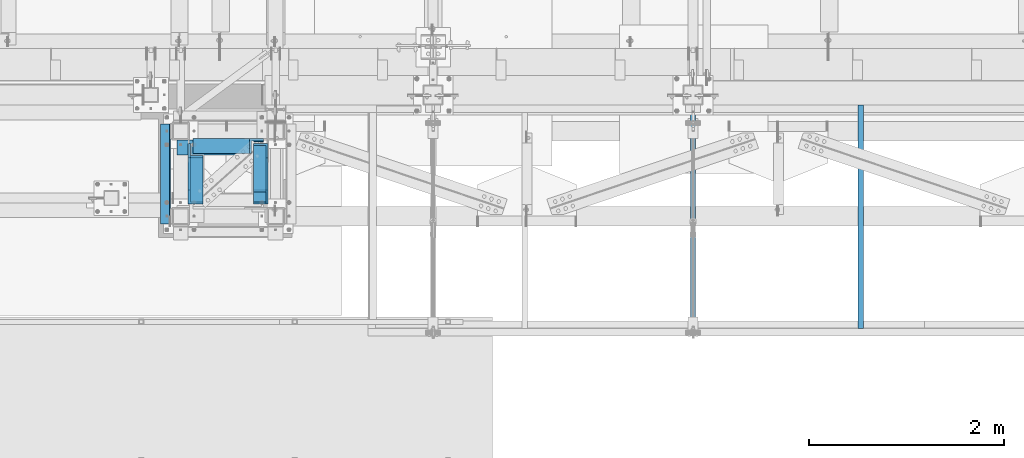
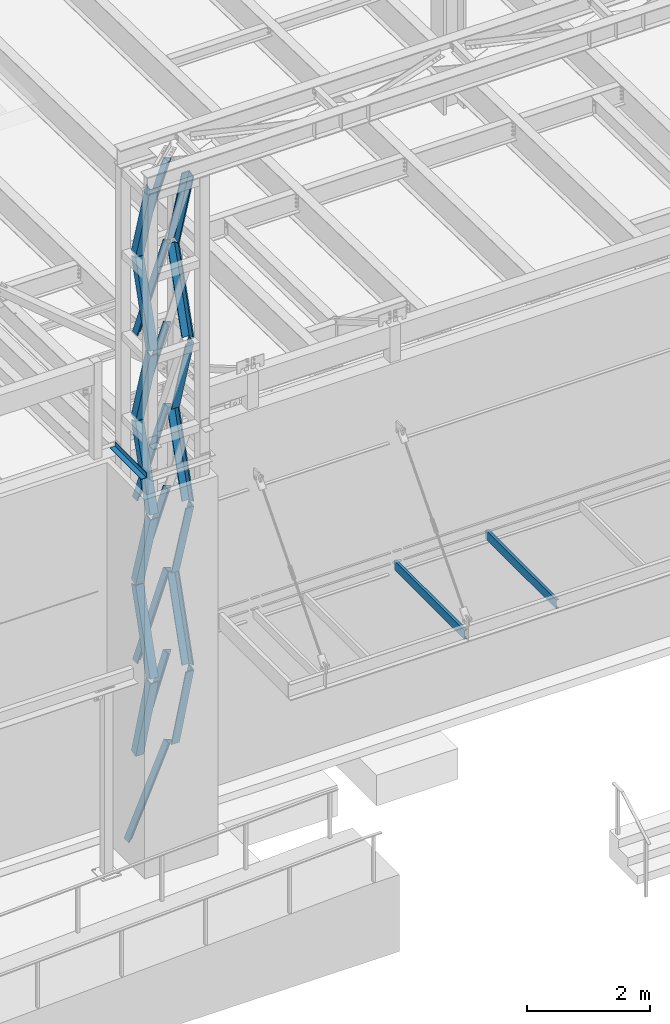
# One storey, part 1053 of 1763: 22 members, 3 beams, 3 elements without a shape of their own.
"""IFC2X3 building model written with IfcOpenShell, lengths in millimetres."""

import ifcopenshell
import ifcopenshell.guid

model = None  # the IFC model being written
_history = None  # IfcOwnerHistory: only IFC2X3 demands one
_inside = {}  # id of a spatial element -> (the spatial element, [elements in it])
_under = {}  # id of a project, library or spatial element -> (it, [spatial elements below it])
_declared = {}  # id of a project -> (the project, [libraries it declares])
_typed = {}  # id of a type object -> (the type object, [elements of that type])
_made_of = {}  # id of a material, layer set ... -> (it, [elements and type objects made of it])


def new_model(schema):
    """Start an empty IFC model of exactly this schema.

    Asked for "IFC4X3", IfcOpenShell would pick the latest addendum, in which some entities
    have other attributes; the version numbers below select the first issue.
    IFC2X3 requires an IfcOwnerHistory on every rooted entity: one is made here for all.
    """
    global model, _history
    if schema == "IFC4X3":
        model = ifcopenshell.file(schema_version=(4, 3, 0, 0))
    else:
        model = ifcopenshell.file(schema=schema)
    _inside.clear()
    _under.clear()
    _declared.clear()
    _typed.clear()
    _made_of.clear()
    _history = None
    if model.schema == "IFC2X3":
        org = make("IfcOrganization", Name="unknown")
        user = make(
            "IfcPersonAndOrganization",
            ThePerson=make("IfcPerson", FamilyName="unknown"),
            TheOrganization=org,
        )
        app = make(
            "IfcApplication",
            ApplicationDeveloper=org,
            Version="unknown",
            ApplicationFullName="unknown",
            ApplicationIdentifier="unknown",
        )
        _history = make(
            "IfcOwnerHistory",
            OwningUser=user,
            OwningApplication=app,
            ChangeAction="ADDED",
            CreationDate=0,
        )
    return model


def make(cls, **values):
    """One entity of the class cls with the attributes given. An attribute that is None is left unset."""
    return model.create_entity(
        cls, **{name: value for name, value in values.items() if value is not None}
    )


def rooted(cls, **values):
    """An entity with a GlobalId (a new one), such as an element, a storey or a relation."""
    return make(cls, GlobalId=ifcopenshell.guid.new(), OwnerHistory=_history, **values)


def si_unit(unit_type, name, prefix=None):
    """IfcSIUnit, for example si_unit("LENGTHUNIT", "METRE", prefix="MILLI")."""
    return make("IfcSIUnit", UnitType=unit_type, Prefix=prefix, Name=name)


def assignment(units):
    """IfcUnitAssignment: the units of a project."""
    return None if units is None else make("IfcUnitAssignment", Units=units)


def point(xyz):
    """IfcCartesianPoint."""
    return None if xyz is None else make("IfcCartesianPoint", Coordinates=xyz)


def direction(xyz):
    """IfcDirection."""
    return None if xyz is None else make("IfcDirection", DirectionRatios=xyz)


def frame(location, z_axis=None, x_axis=None):
    """IfcAxis2Placement3D, a coordinate frame: its origin and axes. An axis left out is left unset."""
    return make(
        "IfcAxis2Placement3D",
        Location=point(location),
        Axis=direction(z_axis),
        RefDirection=direction(x_axis),
    )


def origin_with_axes():
    """The frame at (0, 0, 0) with the z axis (0, 0, 1) and the x axis (1, 0, 0) written out."""
    return frame((0.0, 0.0, 0.0), z_axis=(0.0, 0.0, 1.0), x_axis=(1.0, 0.0, 0.0))


def place(relative_to, where):
    """IfcLocalPlacement: puts the frame where relative to a parent placement (None: the world)."""
    return make(
        "IfcLocalPlacement", PlacementRelTo=relative_to, RelativePlacement=where
    )


def context(
    kind, dimensions, precision=None, world=None, true_north=None, identifier=None
):
    """IfcGeometricRepresentationContext, for example the 3D "Model" context."""
    return make(
        "IfcGeometricRepresentationContext",
        ContextIdentifier=identifier,
        ContextType=kind,
        CoordinateSpaceDimension=dimensions,
        Precision=precision,
        WorldCoordinateSystem=world,
        TrueNorth=true_north,
    )


def subcontext(parent, identifier, kind, view, scale=None):
    """IfcGeometricRepresentationSubContext, for example "Body" below "Model"."""
    return make(
        "IfcGeometricRepresentationSubContext",
        ContextIdentifier=identifier,
        ContextType=kind,
        ParentContext=parent,
        TargetScale=scale,
        TargetView=view,
    )


def project(units=None, contexts=None):
    """IfcProject with its units and contexts."""
    return rooted(
        "IfcProject",
        Name="project",
        RepresentationContexts=contexts,
        UnitsInContext=assignment(units),
    )


def spatial(cls, under=None, at=None, **own):
    """A site, building, storey or space (cls), placed at a placement, below another one or the project."""
    s = rooted(cls, ObjectPlacement=at, **own)
    if under is not None:
        _under.setdefault(under.id(), (under, []))[1].append(s)
    return s


def faces_of(points, faces, orient=None, outer=None):
    """IfcFace entities. A face is a list of loops; a loop is a list of indices into points, from 0.

    orient and outer hold one flag for each loop. By default every Orientation is true, the
    first loop of a face is its IfcFaceOuterBound and the others are IfcFaceBound.
    """
    made = []
    for i, loops in enumerate(faces):
        bounds = []
        for j, loop in enumerate(loops):
            is_outer = j == 0 if outer is None else outer[i][j]
            bounds.append(
                make(
                    "IfcFaceOuterBound" if is_outer else "IfcFaceBound",
                    Bound=make("IfcPolyLoop", Polygon=[points[k] for k in loop]),
                    Orientation=True if orient is None else orient[i][j],
                )
            )
        made.append(make("IfcFace", Bounds=bounds))
    return made


def faceted_brep(points, faces, orient=None, outer=None, voids=None):
    """IfcFacetedBrep: a solid bounded by flat faces; with voids (closed shells), ...WithVoids."""
    shared = [point(p) for p in points]
    hull = make("IfcClosedShell", CfsFaces=faces_of(shared, faces, orient, outer))
    if voids is None:
        return make("IfcFacetedBrep", Outer=hull)
    return make(
        "IfcFacetedBrepWithVoids",
        Outer=hull,
        Voids=[
            make(cls, CfsFaces=faces_of(shared, fs, o, b)) for cls, fs, o, b in voids
        ],
    )


def shape(context_of_items, identifier, shape_type, items):
    """IfcShapeRepresentation: the items that make up one representation, for example the "Body"."""
    return make(
        "IfcShapeRepresentation",
        ContextOfItems=context_of_items,
        RepresentationIdentifier=identifier,
        RepresentationType=shape_type,
        Items=items,
    )


def material(Name=None, Category=None):
    """IfcMaterial."""
    return make("IfcMaterial", Name=Name, Category=Category)


def made_of(thing, what):
    """Note that an element or type object is made of a material, layer set ...; save() writes the relation."""
    if what is not None:
        _made_of.setdefault(what.id(), (what, []))[1].append(thing)
    return thing


def type_object(cls, material=None, **own):
    """A type object (cls), such as IfcWallType, which elements share."""
    return made_of(rooted(cls, **own), material)


def element(
    cls,
    number,
    at=None,
    inside=None,
    cuts=None,
    type_object=None,
    material=None,
    context=None,
    identifier="Body",
    shape_type=None,
    held_by="IfcProductDefinitionShape",
    body=None,
    shapes=None,
    **own,
):
    """One element of the class cls, such as IfcWall. Its Tag is "e" and its number.

    at: its placement. inside: the storey or other place that contains it. cuts: it is an
    opening in that element (IfcRelVoidsElement). A single representation is given by context,
    identifier, shape_type and body (its items); several are given by shapes. held_by: the class
    of the entity that holds the representations. save() writes the other relations.
    """
    e = rooted(cls, Tag="e%d" % number, ObjectPlacement=at, **own)
    if body is not None:
        shapes = [shape(context, identifier, shape_type, body)]
    if shapes is not None:
        e.Representation = make(held_by, Representations=shapes)
    if inside is not None:
        _inside.setdefault(inside.id(), (inside, []))[1].append(e)
    if cuts is not None:
        rooted(
            "IfcRelVoidsElement", RelatingBuildingElement=cuts, RelatedOpeningElement=e
        )
    if type_object is not None:
        _typed.setdefault(type_object.id(), (type_object, []))[1].append(e)
    return made_of(e, material)


def aggregate(whole, parts):
    """IfcRelAggregates: a whole, such as a stair, and the parts it consists of."""
    return rooted("IfcRelAggregates", RelatingObject=whole, RelatedObjects=parts)


def save(model, path):
    """Write the relations noted so far, then the file.

    IfcRelAggregates (storeys below a building ...), IfcRelContainedInSpatialStructure (elements
    in a storey), IfcRelDefinesByType, IfcRelAssociatesMaterial and IfcRelDeclares: one each for
    every whole, place, type object, material and project.
    """
    for whole, parts in _under.values():
        aggregate(whole, parts)
    for where, things in _inside.values():
        rooted(
            "IfcRelContainedInSpatialStructure",
            RelatedElements=things,
            RelatingStructure=where,
        )
    for kind, things in _typed.values():
        rooted("IfcRelDefinesByType", RelatedObjects=things, RelatingType=kind)
    for what, things in _made_of.values():
        rooted("IfcRelAssociatesMaterial", RelatedObjects=things, RelatingMaterial=what)
    for by, libraries in _declared.values():
        rooted("IfcRelDeclares", RelatingContext=by, RelatedDefinitions=libraries)
    model.write(path)


model = new_model("IFC2X3")

# Units and contexts
model_context = context("Model", 3, precision=1e-05, world=origin_with_axes())
body_context = subcontext(model_context, "Body", "Model", "MODEL_VIEW")
ifc_project = project(units=[si_unit("LENGTHUNIT", "METRE", prefix="MILLI"), si_unit("AREAUNIT", "SQUARE_METRE"), si_unit("VOLUMEUNIT", "CUBIC_METRE"), si_unit("MASSUNIT", "GRAM", prefix="KILO"), si_unit("TIMEUNIT", "SECOND"), si_unit("PLANEANGLEUNIT", "RADIAN"), si_unit("SOLIDANGLEUNIT", "STERADIAN"), si_unit("THERMODYNAMICTEMPERATUREUNIT", "DEGREE_CELSIUS"), si_unit("LUMINOUSINTENSITYUNIT", "LUMEN")], contexts=[model_context])

# Site, building, storey
site_placement = place(None, origin_with_axes())
site = spatial("IfcSite", under=ifc_project, at=site_placement, CompositionType="ELEMENT")
building_placement = place(site_placement, origin_with_axes())
building = spatial("IfcBuilding", under=site, at=building_placement, Name="Undefined", CompositionType="ELEMENT")
storey_placement = place(building_placement, origin_with_axes())
storey = spatial("IfcBuildingStorey", under=building, at=storey_placement, Name="Undefined", CompositionType="ELEMENT", Elevation=0.0)

# Assembly, members, beam
assembly_1_placement = place(storey_placement, origin_with_axes())
assembly_1 = element("IfcElementAssembly", 1, at=assembly_1_placement, inside=storey, Name="FRAME", AssemblyPlace="NOTDEFINED", PredefinedType="RIGID_FRAME")
ifc_material = material(Name="STEEL/A36")
member_type = type_object("IfcMemberType", Name="L6X6X7/8", PredefinedType="NOTDEFINED")
member_1_placement = place(assembly_1_placement, frame((-63362.9025956311, -14779.1377588466, 16774.1203123683), z_axis=(-1.0, 0.0, 0.0), x_axis=(0.0, -0.28425468487658, 0.958748806583725)))
member_1 = element("IfcMember", 2, at=member_1_placement, type_object=member_type, material=ifc_material, Name="V. BRACE", ObjectType="L6X6X7/8", context=body_context, shape_type="Brep", body=[
    faceted_brep([(1.81898940354586e-12, -76.2000000000007, -53.9750000000604), (9.09494701772928e-13, -76.2000000000007, -76.2000000000844), (1668.42939139346, -76.2000000002827, -76.1999999999971), (1668.42939139346, -76.2000000002827, -53.9749999999985), (1.81898940354586e-12, 53.9750000000004, -53.9750000000604), (1668.42939139347, 53.9749999998239, -53.9749999999985), (0.0, 53.9750000000004, 76.2000000000771), (1668.42939139347, 53.9749999998239, 76.1999999999971), (0.0, 76.2000000000007, 76.2000000000771), (1668.42939139347, 76.1999999998425, 76.1999999999971), (9.09494701772928e-13, 76.2000000000007, -76.2000000000844), (1668.42939139347, 76.1999999998425, -76.1999999999971)], [[[0, 1, 2, 3]], [[4, 0, 3, 5]], [[6, 4, 5, 7]], [[8, 6, 7, 9]], [[1, 0, 4, 6, 8, 10]], [[1, 10, 11, 2]], [[7, 5, 3, 2, 11, 9]], [[10, 8, 9, 11]]]),
])
member_2_placement = place(assembly_1_placement, frame((-63362.9025956311, -14778.8697265793, 13524.110936), z_axis=(0.0, 0.957075661201097, 0.2898381940609), x_axis=(0.0, -0.2898381940609, 0.957075661201097)))
member_2 = element("IfcMember", 3, at=member_2_placement, type_object=member_type, material=ifc_material, Name="V. BRACE", ObjectType="L6X6X7/8", context=body_context, shape_type="Brep", body=[
    faceted_brep([(9.09494701772928e-13, 76.2000000000007, -76.2000000000844), (0.0, 76.2000000000007, 76.2000000000771), (1639.83084289621, 76.1999999999971, 76.1999999993677), (1639.83084289615, 76.1999999999971, -76.2000000006465), (0.0, 53.9750000000004, 76.2000000000771), (1639.83084289621, 53.9749999999985, 76.1999999993677), (1.81898940354586e-12, 53.9750000000004, -53.9750000000604), (1639.83084289616, 53.9749999999985, -53.9750000006443), (1.81898940354586e-12, -76.2000000000007, -53.9750000000604), (1639.83084289616, -76.1999999999971, -53.9750000006443), (9.09494701772928e-13, -76.2000000000007, -76.2000000000844), (1639.83084289615, -76.1999999999971, -76.2000000006465)], [[[0, 1, 2, 3]], [[1, 4, 5, 2]], [[4, 6, 7, 5]], [[6, 8, 9, 7]], [[8, 10, 11, 9]], [[10, 0, 3, 11]], [[5, 7, 9, 11, 3, 2]], [[10, 8, 6, 4, 1, 0]]]),
])
member_3_placement = place(assembly_1_placement, frame((-63362.9025956311, -15253.4501586902, 15149.115624), z_axis=(-1.0, 0.0, 0.0), x_axis=(0.0, 0.289497082081885, 0.957178896270741)))
member_3 = element("IfcMember", 4, at=member_3_placement, type_object=member_type, material=ifc_material, Name="V. BRACE", ObjectType="L6X6X7/8", context=body_context, shape_type="Brep", body=[
    faceted_brep([(9.09494701772928e-13, 76.2000000000007, -76.2000000000844), (0.0, 76.2000000000007, 76.2000000000771), (1639.65398114875, 76.1999999994368, 76.1999999999971), (1639.65398114875, 76.1999999994368, -76.1999999999971), (0.0, 53.9750000000004, 76.2000000000771), (1639.65398114874, 53.9749999994274, 76.1999999999971), (1.81898940354586e-12, 53.9750000000004, -53.9750000000604), (1639.65398114874, 53.9749999994274, -53.9749999999985), (1.81898940354586e-12, -76.2000000000007, -53.9750000000604), (1639.6539811487, -76.2000000006228, -53.9749999999985), (9.09494701772928e-13, -76.2000000000007, -76.2000000000844), (1639.6539811487, -76.2000000006228, -76.1999999999971)], [[[0, 1, 2, 3]], [[1, 4, 5, 2]], [[4, 6, 7, 5]], [[6, 8, 9, 7]], [[8, 10, 11, 9]], [[10, 0, 3, 11]], [[5, 7, 9, 11, 3, 2]], [[10, 8, 6, 4, 1, 0]]]),
])
member_4_placement = place(assembly_1_placement, frame((-63363.1560346877, -14778.8362458636, 10274.101560012), z_axis=(-0.00051033699985419, 0.95707420473217, 0.289842554143505), x_axis=(0.000154551999968596, -0.28984251293782, 0.957074340794679)))
member_4 = element("IfcMember", 5, at=member_4_placement, type_object=member_type, material=ifc_material, Name="V. BRACE", ObjectType="L6X6X7/8", context=body_context, shape_type="Brep", body=[
    faceted_brep([(9.09494701772928e-13, 76.2000000000007, -76.2000000000844), (0.0, 76.2000000000007, 76.2000000000771), (1639.83084289621, 76.1999999999971, 76.1999999993677), (1639.83084289615, 76.1999999999971, -76.2000000006465), (0.0, 53.9750000000004, 76.2000000000771), (1639.83084289621, 53.9749999999985, 76.1999999993677), (1.81898940354586e-12, 53.9750000000004, -53.9750000000604), (1639.83084289616, 53.9749999999985, -53.9750000006443), (1.81898940354586e-12, -76.2000000000007, -53.9750000000604), (1639.83084289616, -76.1999999999971, -53.9750000006443), (9.09494701772928e-13, -76.2000000000007, -76.2000000000844), (1639.83084289615, -76.1999999999971, -76.2000000006465)], [[[0, 1, 2, 3]], [[1, 4, 5, 2]], [[4, 6, 7, 5]], [[6, 8, 9, 7]], [[8, 10, 11, 9]], [[10, 0, 3, 11]], [[5, 7, 9, 11, 3, 2]], [[10, 8, 6, 4, 1, 0]]]),
])
member_5_placement = place(assembly_1_placement, frame((-63362.9025956311, -15253.4581785514, 11899.106248), z_axis=(-1.0, 0.0, 0.0), x_axis=(0.0, 0.289837226101388, 0.957075954334792)))
member_5 = element("IfcMember", 6, at=member_5_placement, type_object=member_type, material=ifc_material, Name="V. BRACE", ObjectType="L6X6X7/8", context=body_context, shape_type="Brep", body=[
    faceted_brep([(9.09494701772928e-13, 76.2000000000007, -76.2000000000844), (0.0, 76.2000000000007, 76.2000000000771), (1639.83084289621, 76.1999999999971, 76.1999999993677), (1639.83084289615, 76.1999999999971, -76.2000000006465), (0.0, 53.9750000000004, 76.2000000000771), (1639.83084289621, 53.9749999999985, 76.1999999993677), (1.81898940354586e-12, 53.9750000000004, -53.9750000000604), (1639.83084289616, 53.9749999999985, -53.9750000006443), (1.81898940354586e-12, -76.2000000000007, -53.9750000000604), (1639.83084289616, -76.1999999999971, -53.9750000006443), (9.09494701772928e-13, -76.2000000000007, -76.2000000000844), (1639.83084289615, -76.1999999999971, -76.2000000006465)], [[[0, 1, 2, 3]], [[1, 4, 5, 2]], [[4, 6, 7, 5]], [[6, 8, 9, 7]], [[8, 10, 11, 9]], [[10, 0, 3, 11]], [[5, 7, 9, 11, 3, 2]], [[10, 8, 6, 4, 1, 0]]]),
])
member_6_placement = place(assembly_1_placement, frame((-63362.9025956311, -14779.5097694224, 6870.7000000123), z_axis=(0.0, 0.964170339699174, 0.26528391591723), x_axis=(0.0, -0.26528391591723, 0.964170339699174)))
member_6 = element("IfcMember", 7, at=member_6_placement, type_object=member_type, material=ifc_material, Name="V. BRACE", ObjectType="L6X6X7/8", context=body_context, shape_type="Brep", body=[
    faceted_brep([(9.09494701772928e-13, 76.2000000000007, -76.2000000000844), (0.0, 76.2000000000007, 76.2000000000771), (1786.4452256684, 76.1999999999971, 76.2000000014923), (1786.44522566839, 76.1999999999971, -76.1999999985128), (0.0, 53.9750000000004, 76.2000000000771), (1786.4452256684, 53.9749999999985, 76.2000000014923), (1.81898940354586e-12, 53.9750000000004, -53.9750000000604), (1786.44522566839, 53.9749999999985, -53.9749999985124), (1.81898940354586e-12, -76.2000000000007, -53.9750000000604), (1786.44522566839, -76.1999999999971, -53.9749999985124), (9.09494701772928e-13, -76.2000000000007, -76.2000000000844), (1786.44522566839, -76.1999999999971, -76.1999999985128)], [[[0, 1, 2, 3]], [[1, 4, 5, 2]], [[4, 6, 7, 5]], [[6, 8, 9, 7]], [[8, 10, 11, 9]], [[10, 0, 3, 11]], [[5, 7, 9, 11, 3, 2]], [[10, 8, 6, 4, 1, 0]]]),
])
member_7_placement = place(assembly_1_placement, frame((-63362.9025956311, -15253.4568741598, 8648.7), z_axis=(-1.0, 0.0, 0.0), x_axis=(0.0, 0.288881147137844, 0.957364968456818)))
member_7 = element("IfcMember", 8, at=member_7_placement, type_object=member_type, material=ifc_material, Name="V. BRACE", ObjectType="L6X6X7/8", context=body_context, shape_type="Brep", body=[
    faceted_brep([(9.09494701772928e-13, 76.2000000000007, -76.2000000000844), (0.0, 76.2000000000007, 76.2000000000771), (1639.74984635749, 76.2000000008557, 76.1999999999971), (1639.74984635749, 76.2000000008557, -76.1999999999971), (0.0, 53.9750000000004, 76.2000000000771), (1639.7498463575, 53.9750000008426, 76.1999999999971), (1.81898940354586e-12, 53.9750000000004, -53.9750000000604), (1639.7498463575, 53.9750000008426, -53.9749999999985), (1.81898940354586e-12, -76.2000000000007, -53.9750000000604), (1639.74984635757, -76.1999999992149, -53.9749999999985), (9.09494701772928e-13, -76.2000000000007, -76.2000000000844), (1639.74984635757, -76.1999999992149, -76.1999999999971)], [[[0, 1, 2, 3]], [[1, 4, 5, 2]], [[4, 6, 7, 5]], [[6, 8, 9, 7]], [[8, 10, 11, 9]], [[10, 0, 3, 11]], [[5, 7, 9, 11, 3, 2]], [[10, 8, 6, 4, 1, 0]]]),
])
member_8_placement = place(assembly_1_placement, frame((-64032.8275956404, -14779.1377595563, 16774.1203120008), z_axis=(1.0, 0.0, 0.0), x_axis=(0.0, -0.28425468487658, 0.958748806583725)))
member_8 = element("IfcMember", 9, at=member_8_placement, type_object=member_type, material=ifc_material, Name="V. BRACE", ObjectType="L6X6X7/8", context=body_context, shape_type="Brep", body=[
    faceted_brep([(1.81898940354586e-12, -76.2000000000007, -53.9750000000604), (9.09494701772928e-13, -76.2000000000007, -76.2000000000844), (1668.42939139346, -76.2000000002827, -76.1999999999971), (1668.42939139346, -76.2000000002827, -53.9749999999985), (1.81898940354586e-12, 53.9750000000004, -53.9750000000604), (1668.42939139347, 53.9749999998239, -53.9749999999985), (0.0, 53.9750000000004, 76.2000000000771), (1668.42939139347, 53.9749999998239, 76.1999999999971), (0.0, 76.2000000000007, 76.2000000000771), (1668.42939139347, 76.1999999998425, 76.1999999999971), (9.09494701772928e-13, 76.2000000000007, -76.2000000000844), (1668.42939139347, 76.1999999998425, -76.1999999999971)], [[[0, 1, 2, 3]], [[4, 0, 3, 5]], [[6, 4, 5, 7]], [[8, 6, 7, 9]], [[1, 0, 4, 6, 8, 10]], [[1, 10, 11, 2]], [[7, 5, 3, 2, 11, 9]], [[10, 8, 9, 11]]]),
])
member_9_placement = place(assembly_1_placement, frame((-64032.8273899732, -14778.8697282808, 13524.110936), z_axis=(1.0, 0.0, 0.0), x_axis=(0.0, -0.2898381940609, 0.957075661201097)))
member_9 = element("IfcMember", 10, at=member_9_placement, type_object=member_type, material=ifc_material, Name="V. BRACE", ObjectType="L6X6X7/8", context=body_context, shape_type="Brep", body=[
    faceted_brep([(9.09494701772928e-13, 76.2000000000007, -76.2000000000844), (0.0, 76.2000000000007, 76.2000000000771), (1639.83084289621, 76.1999999999971, 76.1999999993677), (1639.83084289615, 76.1999999999971, -76.2000000006465), (0.0, 53.9750000000004, 76.2000000000771), (1639.83084289621, 53.9749999999985, 76.1999999993677), (1.81898940354586e-12, 53.9750000000004, -53.9750000000604), (1639.83084289616, 53.9749999999985, -53.9750000006443), (1.81898940354586e-12, -76.2000000000007, -53.9750000000604), (1639.83084289616, -76.1999999999971, -53.9750000006443), (9.09494701772928e-13, -76.2000000000007, -76.2000000000844), (1639.83084289615, -76.1999999999971, -76.2000000006465)], [[[0, 1, 2, 3]], [[1, 4, 5, 2]], [[4, 6, 7, 5]], [[6, 8, 9, 7]], [[8, 10, 11, 9]], [[10, 0, 3, 11]], [[5, 7, 9, 11, 3, 2]], [[10, 8, 6, 4, 1, 0]]]),
])
member_10_placement = place(assembly_1_placement, frame((-64032.8273899732, -15253.4501603916, 15149.115624), z_axis=(1.0, 0.0, 0.0), x_axis=(0.0, 0.289497082081885, 0.957178896270741)))
member_10 = element("IfcMember", 11, at=member_10_placement, type_object=member_type, material=ifc_material, Name="V. BRACE", ObjectType="L6X6X7/8", context=body_context, shape_type="Brep", body=[
    faceted_brep([(9.09494701772928e-13, 76.2000000000007, -76.2000000000844), (0.0, 76.2000000000007, 76.2000000000771), (1639.65398114875, 76.1999999994368, 76.1999999999971), (1639.65398114875, 76.1999999994368, -76.1999999999971), (0.0, 53.9750000000004, 76.2000000000771), (1639.65398114874, 53.9749999994274, 76.1999999999971), (1.81898940354586e-12, 53.9750000000004, -53.9750000000604), (1639.65398114874, 53.9749999994274, -53.9749999999985), (1.81898940354586e-12, -76.2000000000007, -53.9750000000604), (1639.6539811487, -76.2000000006228, -53.9749999999985), (9.09494701772928e-13, -76.2000000000007, -76.2000000000844), (1639.6539811487, -76.2000000006228, -76.1999999999971)], [[[0, 1, 2, 3]], [[1, 4, 5, 2]], [[4, 6, 7, 5]], [[6, 8, 9, 7]], [[8, 10, 11, 9]], [[10, 0, 3, 11]], [[5, 7, 9, 11, 3, 2]], [[10, 8, 6, 4, 1, 0]]]),
])
member_11_placement = place(assembly_1_placement, frame((-64033.0808290298, -14778.8362475651, 10274.101560012), z_axis=(0.999999857834454, 0.000533227035961318, -1.19036485557445e-10), x_axis=(0.000154551999968596, -0.28984251293782, 0.957074340794679)))
member_11 = element("IfcMember", 12, at=member_11_placement, type_object=member_type, material=ifc_material, Name="V. BRACE", ObjectType="L6X6X7/8", context=body_context, shape_type="Brep", body=[
    faceted_brep([(9.09494701772928e-13, 76.2000000000007, -76.2000000000844), (0.0, 76.2000000000007, 76.2000000000771), (1639.83084289621, 76.1999999999971, 76.1999999993677), (1639.83084289615, 76.1999999999971, -76.2000000006465), (0.0, 53.9750000000004, 76.2000000000771), (1639.83084289621, 53.9749999999985, 76.1999999993677), (1.81898940354586e-12, 53.9750000000004, -53.9750000000604), (1639.83084289616, 53.9749999999985, -53.9750000006443), (1.81898940354586e-12, -76.2000000000007, -53.9750000000604), (1639.83084289616, -76.1999999999971, -53.9750000006443), (9.09494701772928e-13, -76.2000000000007, -76.2000000000844), (1639.83084289615, -76.1999999999971, -76.2000000006465)], [[[0, 1, 2, 3]], [[1, 4, 5, 2]], [[4, 6, 7, 5]], [[6, 8, 9, 7]], [[8, 10, 11, 9]], [[10, 0, 3, 11]], [[5, 7, 9, 11, 3, 2]], [[10, 8, 6, 4, 1, 0]]]),
])
member_12_placement = place(assembly_1_placement, frame((-64032.8273899732, -15253.4581802529, 11899.106248), z_axis=(1.0, 0.0, 0.0), x_axis=(0.0, 0.289837226101388, 0.957075954334792)))
member_12 = element("IfcMember", 13, at=member_12_placement, type_object=member_type, material=ifc_material, Name="V. BRACE", ObjectType="L6X6X7/8", context=body_context, shape_type="Brep", body=[
    faceted_brep([(9.09494701772928e-13, 76.2000000000007, -76.2000000000844), (0.0, 76.2000000000007, 76.2000000000771), (1639.83084289621, 76.1999999999971, 76.1999999993677), (1639.83084289615, 76.1999999999971, -76.2000000006465), (0.0, 53.9750000000004, 76.2000000000771), (1639.83084289621, 53.9749999999985, 76.1999999993677), (1.81898940354586e-12, 53.9750000000004, -53.9750000000604), (1639.83084289616, 53.9749999999985, -53.9750000006443), (1.81898940354586e-12, -76.2000000000007, -53.9750000000604), (1639.83084289616, -76.1999999999971, -53.9750000006443), (9.09494701772928e-13, -76.2000000000007, -76.2000000000844), (1639.83084289615, -76.1999999999971, -76.2000000006465)], [[[0, 1, 2, 3]], [[1, 4, 5, 2]], [[4, 6, 7, 5]], [[6, 8, 9, 7]], [[8, 10, 11, 9]], [[10, 0, 3, 11]], [[5, 7, 9, 11, 3, 2]], [[10, 8, 6, 4, 1, 0]]]),
])
member_13_placement = place(assembly_1_placement, frame((-64032.8273899732, -14779.5097711238, 6870.7000000123), z_axis=(1.0, 0.0, 0.0), x_axis=(0.0, -0.26528391591723, 0.964170339699174)))
member_13 = element("IfcMember", 14, at=member_13_placement, type_object=member_type, material=ifc_material, Name="V. BRACE", ObjectType="L6X6X7/8", context=body_context, shape_type="Brep", body=[
    faceted_brep([(9.09494701772928e-13, 76.2000000000007, -76.2000000000844), (0.0, 76.2000000000007, 76.2000000000771), (1786.4452256684, 76.1999999999971, 76.2000000014923), (1786.44522566839, 76.1999999999971, -76.1999999985128), (0.0, 53.9750000000004, 76.2000000000771), (1786.4452256684, 53.9749999999985, 76.2000000014923), (1.81898940354586e-12, 53.9750000000004, -53.9750000000604), (1786.44522566839, 53.9749999999985, -53.9749999985124), (1.81898940354586e-12, -76.2000000000007, -53.9750000000604), (1786.44522566839, -76.1999999999971, -53.9749999985124), (9.09494701772928e-13, -76.2000000000007, -76.2000000000844), (1786.44522566839, -76.1999999999971, -76.1999999985128)], [[[0, 1, 2, 3]], [[1, 4, 5, 2]], [[4, 6, 7, 5]], [[6, 8, 9, 7]], [[8, 10, 11, 9]], [[10, 0, 3, 11]], [[5, 7, 9, 11, 3, 2]], [[10, 8, 6, 4, 1, 0]]]),
])
member_14_placement = place(assembly_1_placement, frame((-64032.8273899732, -15253.4568758613, 8648.7), z_axis=(1.0, 0.0, 0.0), x_axis=(0.0, 0.288881147137844, 0.957364968456818)))
member_14 = element("IfcMember", 15, at=member_14_placement, type_object=member_type, material=ifc_material, Name="V. BRACE", ObjectType="L6X6X7/8", context=body_context, shape_type="Brep", body=[
    faceted_brep([(9.09494701772928e-13, 76.2000000000007, -76.2000000000844), (0.0, 76.2000000000007, 76.2000000000771), (1639.74984635749, 76.2000000008557, 76.1999999999971), (1639.74984635749, 76.2000000008557, -76.1999999999971), (0.0, 53.9750000000004, 76.2000000000771), (1639.7498463575, 53.9750000008426, 76.1999999999971), (1.81898940354586e-12, 53.9750000000004, -53.9750000000604), (1639.7498463575, 53.9750000008426, -53.9749999999985), (1.81898940354586e-12, -76.2000000000007, -53.9750000000604), (1639.74984635757, -76.1999999992149, -53.9749999999985), (9.09494701772928e-13, -76.2000000000007, -76.2000000000844), (1639.74984635757, -76.1999999992149, -76.1999999999971)], [[[0, 1, 2, 3]], [[1, 4, 5, 2]], [[4, 6, 7, 5]], [[6, 8, 9, 7]], [[8, 10, 11, 9]], [[10, 0, 3, 11]], [[5, 7, 9, 11, 3, 2]], [[10, 8, 6, 4, 1, 0]]]),
])
member_15_placement = place(assembly_1_placement, frame((-63987.020526009, -14732.0027335079, 16748.720536701), z_axis=(6.06694512680406e-06, -0.999999999981596, -1.54199369717389e-10), x_axis=(0.335283282133074, 2.03400000119903e-06, 0.942117360373927)))
member_15 = element("IfcMember", 16, at=member_15_placement, type_object=member_type, material=ifc_material, Name="V. BRACE", ObjectType="L6X6X7/8", context=body_context, shape_type="Brep", body=[
    faceted_brep([(9.09494701772928e-13, 76.2000000000007, -76.2000000000844), (0.0, 76.2000000000007, 76.2000000000771), (1724.84329343789, 76.1999999996478, 76.2000000010958), (1724.84329343754, 76.2000000000044, -76.1999999989348), (0.0, 53.9750000000004, 76.2000000000771), (1724.84329343786, 53.9749999996711, 76.2000000010812), (1.81898940354586e-12, 53.9750000000004, -53.9750000000604), (1724.84329343756, 53.9749999999767, -53.9749999989453), (1.81898940354586e-12, -76.2000000000007, -53.9750000000604), (1724.84329343738, -76.1999999998734, -53.9749999990436), (9.09494701772928e-13, -76.2000000000007, -76.2000000000844), (1724.84329343733, -76.1999999998225, -76.1999999990512)], [[[0, 1, 2, 3]], [[1, 4, 5, 2]], [[4, 6, 7, 5]], [[6, 8, 9, 7]], [[8, 10, 11, 9]], [[10, 0, 3, 11]], [[5, 7, 9, 11, 3, 2]], [[10, 8, 6, 4, 1, 0]]]),
])
member_16_placement = place(assembly_1_placement, frame((-63986.7900655412, -14732.0030617525, 15123.715407458), z_axis=(0.0, -1.0, 0.0), x_axis=(0.334874224906127, 9.99999833869425e-10, 0.942262836735866)))
member_16 = element("IfcMember", 17, at=member_16_placement, type_object=member_type, material=ifc_material, Name="V. BRACE", ObjectType="L6X6X7/8", context=body_context, shape_type="Brep", body=[
    faceted_brep([(9.09494701772928e-13, 76.2000000000007, -76.2000000000844), (0.0, 76.2000000000007, 76.2000000000771), (1724.57686399414, 76.1999999983163, 76.1999999992258), (1724.57686399422, 76.1999999981927, -76.2000000007738), (0.0, 53.9750000000004, 76.2000000000771), (1724.57686399418, 53.974999998245, 76.1999999992295), (1.81898940354586e-12, 53.9750000000004, -53.9750000000604), (1724.57686399425, 53.9749999981432, -53.9750000007716), (1.81898940354586e-12, -76.2000000000007, -53.9750000000604), (1724.57686399449, -76.2000000022381, -53.9750000007571), (9.09494701772928e-13, -76.2000000000007, -76.2000000000844), (1724.5768639945, -76.2000000022599, -76.2000000007574)], [[[0, 1, 2, 3]], [[1, 4, 5, 2]], [[4, 6, 7, 5]], [[6, 8, 9, 7]], [[8, 10, 11, 9]], [[10, 0, 3, 11]], [[5, 7, 9, 11, 3, 2]], [[10, 8, 6, 4, 1, 0]]]),
])
member_17_placement = place(assembly_1_placement, frame((-63987.4603618292, -14732.0030617525, 13498.710719458), z_axis=(0.0, -1.0, 0.0), x_axis=(0.335697148961641, 9.99999941453763e-10, 0.941969969892367)))
member_17 = element("IfcMember", 18, at=member_17_placement, type_object=member_type, material=ifc_material, Name="V. BRACE", ObjectType="L6X6X7/8", context=body_context, shape_type="Brep", body=[
    faceted_brep([(9.09494701772928e-13, 76.2000000000007, -76.2000000000844), (0.0, 76.2000000000007, 76.2000000000771), (1725.11328041713, 76.1999999975596, 76.1999999991767), (1725.11328041723, 76.1999999976688, -76.2000000008229), (0.0, 53.9750000000004, 76.2000000000771), (1725.11328041714, 53.9749999975757, 76.1999999991931), (1.81898940354586e-12, 53.9750000000004, -53.9750000000604), (1725.11328041723, 53.9749999976702, -53.975000000808), (1.81898940354586e-12, -76.2000000000007, -53.9750000000604), (1725.11328041727, -76.2000000022526, -53.9750000007098), (9.09494701772928e-13, -76.2000000000007, -76.2000000000844), (1725.11328041728, -76.2000000022454, -76.2000000007101)], [[[0, 1, 2, 3]], [[1, 4, 5, 2]], [[4, 6, 7, 5]], [[6, 8, 9, 7]], [[8, 10, 11, 9]], [[10, 0, 3, 11]], [[5, 7, 9, 11, 3, 2]], [[10, 8, 6, 4, 1, 0]]]),
])
member_18_placement = place(assembly_1_placement, frame((-63986.5973562665, -14732.0030617525, 11849.099783458), z_axis=(0.0, -1.0, 0.0), x_axis=(0.330549340153199, 9.99999554506466e-10, 0.943788712437421)))
member_18 = element("IfcMember", 19, at=member_18_placement, type_object=member_type, material=ifc_material, Name="V. BRACE", ObjectType="L6X6X7/8", context=body_context, shape_type="Brep", body=[
    faceted_brep([(9.09494701772928e-13, 76.2000000000007, -76.2000000000844), (0.0, 76.2000000000007, 76.2000000000771), (1747.86042051722, 76.1999999938562, 76.199999999164), (1747.86042051722, 76.1999999937107, -76.2000000008356), (0.0, 53.9750000000004, 76.2000000000771), (1747.86042051722, 53.9749999938722, 76.1999999991804), (1.81898940354586e-12, 53.9750000000004, -53.9750000000604), (1747.86042051722, 53.9749999937558, -53.9750000008189), (1.81898940354586e-12, -76.2000000000007, -53.9750000000604), (1747.86042051721, -76.2000000061671, -53.9750000007189), (9.09494701772928e-13, -76.2000000000007, -76.2000000000844), (1747.86042051721, -76.2000000061889, -76.2000000007192)], [[[0, 1, 2, 3]], [[1, 4, 5, 2]], [[4, 6, 7, 5]], [[6, 8, 9, 7]], [[8, 10, 11, 9]], [[10, 0, 3, 11]], [[5, 7, 9, 11, 3, 2]], [[10, 8, 6, 4, 1, 0]]]),
])
member_19_placement = place(assembly_1_placement, frame((-63986.1285301326, -14732.0030617525, 10248.70156), z_axis=(0.0, -1.0, 0.0), x_axis=(0.33466183911998, 9.99999794265608e-10, 0.942338290337834)))
member_19 = element("IfcMember", 20, at=member_19_placement, type_object=member_type, material=ifc_material, Name="V. BRACE", ObjectType="L6X6X7/8", context=body_context, shape_type="Brep", body=[
    faceted_brep([(9.09494701772928e-13, 76.2000000000007, -76.2000000000844), (0.0, 76.2000000000007, 76.2000000000771), (1724.4605169534, 76.1999999968903, 76.199999999204), (1724.46051695335, 76.1999999966574, -76.2000000007956), (0.0, 53.9750000000004, 76.2000000000771), (1724.46051695341, 53.9749999968262, 76.1999999992131), (1.81898940354586e-12, 53.9750000000004, -53.9750000000604), (1724.46051695337, 53.9749999966371, -53.975000000788), (1.81898940354586e-12, -76.2000000000007, -53.9750000000604), (1724.46051695341, -76.2000000037297, -53.9750000007334), (9.09494701772928e-13, -76.2000000000007, -76.2000000000844), (1724.4605169534, -76.2000000037588, -76.2000000007338)], [[[0, 1, 2, 3]], [[1, 4, 5, 2]], [[4, 6, 7, 5]], [[6, 8, 9, 7]], [[8, 10, 11, 9]], [[10, 0, 3, 11]], [[5, 7, 9, 11, 3, 2]], [[10, 8, 6, 4, 1, 0]]]),
])
member_20_placement = place(assembly_1_placement, frame((-63986.7094946809, -14732.0030617525, 8623.29978345798), z_axis=(0.0, -1.0, 0.0), x_axis=(0.334512951060313, 1.00000043783993e-09, 0.942391153169914)))
member_20 = element("IfcMember", 21, at=member_20_placement, type_object=member_type, material=ifc_material, Name="V. BRACE", ObjectType="L6X6X7/8", context=body_context, shape_type="Brep", body=[
    faceted_brep([(9.09494701772928e-13, 76.2000000000007, -76.2000000000844), (0.0, 76.2000000000007, 76.2000000000771), (1724.76317823229, 76.1999999951586, 76.1999999991876), (1724.76317823233, 76.199999994933, -76.200000000812), (0.0, 53.9750000000004, 76.2000000000771), (1724.7631782323, 53.97499999516, 76.1999999992004), (1.81898940354586e-12, 53.9750000000004, -53.9750000000604), (1724.76317823234, 53.9749999949636, -53.9750000007989), (1.81898940354586e-12, -76.2000000000007, -53.9750000000604), (1724.76317823241, -76.2000000050757, -53.975000000717), (9.09494701772928e-13, -76.2000000000007, -76.2000000000844), (1724.76317823241, -76.2000000050975, -76.2000000007174)], [[[0, 1, 2, 3]], [[1, 4, 5, 2]], [[4, 6, 7, 5]], [[6, 8, 9, 7]], [[8, 10, 11, 9]], [[10, 0, 3, 11]], [[5, 7, 9, 11, 3, 2]], [[10, 8, 6, 4, 1, 0]]]),
])
member_21_placement = place(assembly_1_placement, frame((-63985.9948915165, -14732.0030617525, 6845.3), z_axis=(0.0, -1.0, 0.0), x_axis=(0.308131522941648, 1.00000004810686e-09, 0.951343767819846)))
member_21 = element("IfcMember", 22, at=member_21_placement, type_object=member_type, material=ifc_material, Name="V. BRACE", ObjectType="L6X6X7/8", context=body_context, shape_type="Brep", body=[
    faceted_brep([(9.09494701772928e-13, 76.2000000000007, -76.2000000000844), (0.0, 76.2000000000007, 76.2000000000771), (1868.93512461962, 76.199999997596, 76.1999999991676), (1868.93512461956, 76.1999999976761, -76.2000000008338), (0.0, 53.9750000000004, 76.2000000000771), (1868.9351246196, 53.9749999976411, 76.1999999991676), (1.81898940354586e-12, 53.9750000000004, -53.9750000000604), (1868.93512461955, 53.9749999977066, -53.9750000008316), (1.81898940354586e-12, -76.2000000000007, -53.9750000000604), (1868.93512461943, -76.2000000020707, -53.975000000828), (9.09494701772928e-13, -76.2000000000007, -76.2000000000844), (1868.93512461942, -76.2000000020489, -76.2000000008265)], [[[0, 1, 2, 3]], [[1, 4, 5, 2]], [[4, 6, 7, 5]], [[6, 8, 9, 7]], [[8, 10, 11, 9]], [[10, 0, 3, 11]], [[5, 7, 9, 11, 3, 2]], [[10, 8, 6, 4, 1, 0]]]),
])
member_22_placement = place(assembly_1_placement, frame((-64185.2277616918, -14744.7030607621, 5067.29978345798), z_axis=(0.0, -1.0, 0.0), x_axis=(0.400955294202786, 1.00000025355767e-09, 0.916097621463323)))
member_22 = element("IfcMember", 23, at=member_22_placement, type_object=member_type, material=ifc_material, Name="V. BRACE", ObjectType="L6X6X7/8", context=body_context, shape_type="Brep", body=[
    faceted_brep([(74.9407141546053, 76.200000000179, -76.2000000000698), (74.9407141245028, 76.1999999999971, 76.1999999999316), (1940.84119258349, 76.2000000036787, 76.1999999991021), (1940.84119258334, 76.2000000038752, -76.2000000008975), (74.9407141244592, 53.9750000000131, 76.1999999999425), (1940.84119258348, 53.9750000036947, 76.1999999991149), (74.9407141501724, 53.9750000001732, -53.9750000000568), (1940.84119258335, 53.9750000038621, -53.9750000008862), (74.9407141499069, -76.1999999997206, -53.9749999999967), (1940.84119258335, -76.199999996039, -53.9750000008244), (74.9407141542943, -76.1999999996842, -76.1999999999953), (1940.84119258333, -76.1999999960099, -76.2000000008247)], [[[0, 1, 2, 3]], [[1, 4, 5, 2]], [[4, 6, 7, 5]], [[6, 8, 9, 7]], [[8, 10, 11, 9]], [[10, 0, 3, 11]], [[5, 7, 9, 11, 3, 2]], [[10, 8, 6, 4, 1, 0]]]),
])
beam_type_1 = type_object("IfcBeamType", Name="L4X4X3/8", PredefinedType="NOTDEFINED")
beam_1_placement = place(assembly_1_placement, frame((-64340.8027910131, -15528.9273151462, 12903.2), z_axis=(-1.0, 0.0, 0.0), x_axis=(0.0, 1.0, 0.0)))
beam_1 = element("IfcBeam", 24, at=beam_1_placement, type_object=beam_type_1, material=ifc_material, Name="ANGLE", ObjectType="L4X4X3/8", context=body_context, shape_type="Brep", body=[
    faceted_brep([(-3.63797880709171e-11, 50.8000000000011, -50.8000000000538), (-1.96450855582952e-10, 50.8000000000393, 50.7999999999374), (1025.5249938965, 50.7999999999993, 50.8000000000029), (1025.5249938965, 50.7999999999993, -50.8000000000029), (0.0, 41.2749999999996, 50.7999999999993), (1025.5249938965, 41.2749999999996, 50.8000000000029), (0.0, 41.2749999999996, -41.2750000000015), (1025.5249938965, 41.2749999999996, -41.2750000000015), (0.0, -50.7999999999993, -41.2750000000015), (1025.5249938965, -50.7999999999993, -41.2750000000015), (2.11002770811319e-10, -50.8000000000357, -50.799999999952), (1025.5249938965, -50.7999999999993, -50.8000000000029)], [[[0, 1, 2, 3]], [[1, 4, 5, 2]], [[4, 6, 7, 5]], [[6, 8, 9, 7]], [[8, 10, 11, 9]], [[10, 0, 3, 11]], [[5, 7, 9, 11, 3, 2]], [[10, 8, 6, 4, 1, 0]]]),
])
aggregate(assembly_1, [beam_1, member_1, member_2, member_3, member_4, member_5, member_6, member_7, member_8, member_9, member_10, member_11, member_12, member_13, member_14, member_15, member_16, member_17, member_18, member_19, member_20, member_21, member_22])

# Assembly, beam
assembly_2_placement = place(storey_placement, origin_with_axes())
assembly_2 = element("IfcElementAssembly", 25, at=assembly_2_placement, inside=storey, Name="BEAM", AssemblyPlace="NOTDEFINED", PredefinedType="RIGID_FRAME")
beam_type_2 = type_object("IfcBeamType", Name="C7X9.8", PredefinedType="NOTDEFINED")
beam_2_placement = place(assembly_2_placement, frame((-57205.7832594637, -16605.2525869262, 8521.7), z_axis=(0.0, 0.0, 1.0), x_axis=(0.0, 1.0, 0.0)))
beam_2 = element("IfcBeam", 26, at=beam_2_placement, type_object=beam_type_2, material=ifc_material, Name="BEAM", ObjectType="C7X9.8", context=body_context, shape_type="Brep", body=[
    faceted_brep([(0.0, 26.9875000000029, -88.8999999999996), (0.0, 26.9875000000029, 88.8999999999996), (2295.52499752098, 26.9875000000029, 88.8999999999996), (2295.52499752098, 26.9875000000029, -88.8999999999996), (0.0, -26.9875000000029, 88.8999999999996), (2295.52499752098, -26.9875000000029, 88.8999999999996), (0.0, -26.9875000000029, 83.8711175000008), (2295.52499752098, -26.9875000000029, 83.8711175000008), (0.0, 22.2249999999985, 75.6723149999998), (2295.52499752098, 22.2249999999985, 75.6723149999998), (0.0, 22.2249999999985, -75.6723149999998), (2295.52499752098, 22.2249999999985, -75.6723149999998), (0.0, -26.9875000000029, -83.8711175000008), (2295.52499752098, -26.9875000000029, -83.8711175000008), (0.0, -26.9875000000029, -88.8999999999996), (2295.52499752098, -26.9875000000029, -88.8999999999996)], [[[0, 1, 2, 3]], [[1, 4, 5, 2]], [[4, 6, 7, 5]], [[6, 8, 9, 7]], [[8, 10, 11, 9]], [[10, 12, 13, 11]], [[12, 14, 15, 13]], [[14, 0, 3, 15]], [[5, 7, 9, 11, 13, 15, 3, 2]], [[14, 12, 10, 8, 6, 4, 1, 0]]]),
])
aggregate(assembly_2, [beam_2])

assembly_3_placement = place(storey_placement, origin_with_axes())
assembly_3 = element("IfcElementAssembly", 27, at=assembly_3_placement, inside=storey, Name="BEAM", AssemblyPlace="NOTDEFINED", PredefinedType="RIGID_FRAME")
beam_3_placement = place(assembly_3_placement, frame((-58927.4270098567, -16605.2525869816, 8521.7), z_axis=(0.0, 0.0, 1.0), x_axis=(0.0, 1.0, 0.0)))
beam_3 = element("IfcBeam", 28, at=beam_3_placement, type_object=beam_type_2, material=ifc_material, Name="BEAM", ObjectType="C7X9.8", context=body_context, shape_type="Brep", body=[
    faceted_brep([(0.0, 26.9875000000029, -88.8999999999996), (0.0, 26.9875000000029, 88.8999999999996), (2295.52499752098, 26.9875000000029, 88.8999999999996), (2295.52499752098, 26.9875000000029, -88.8999999999996), (0.0, -26.9875000000029, 88.8999999999996), (2295.52499752098, -26.9875000000029, 88.8999999999996), (0.0, -26.9875000000029, 83.8711175000008), (2295.52499752098, -26.9875000000029, 83.8711175000008), (0.0, 22.2249999999985, 75.6723149999998), (2295.52499752098, 22.2249999999985, 75.6723149999998), (0.0, 22.2249999999985, -75.6723149999998), (2295.52499752098, 22.2249999999985, -75.6723149999998), (0.0, -26.9875000000029, -83.8711175000008), (2295.52499752098, -26.9875000000029, -83.8711175000008), (0.0, -26.9875000000029, -88.8999999999996), (2295.52499752098, -26.9875000000029, -88.8999999999996)], [[[0, 1, 2, 3]], [[1, 4, 5, 2]], [[4, 6, 7, 5]], [[6, 8, 9, 7]], [[8, 10, 11, 9]], [[10, 12, 13, 11]], [[12, 14, 15, 13]], [[14, 0, 3, 15]], [[5, 7, 9, 11, 13, 15, 3, 2]], [[14, 12, 10, 8, 6, 4, 1, 0]]]),
])
aggregate(assembly_3, [beam_3])

save(model, "model.ifc")
